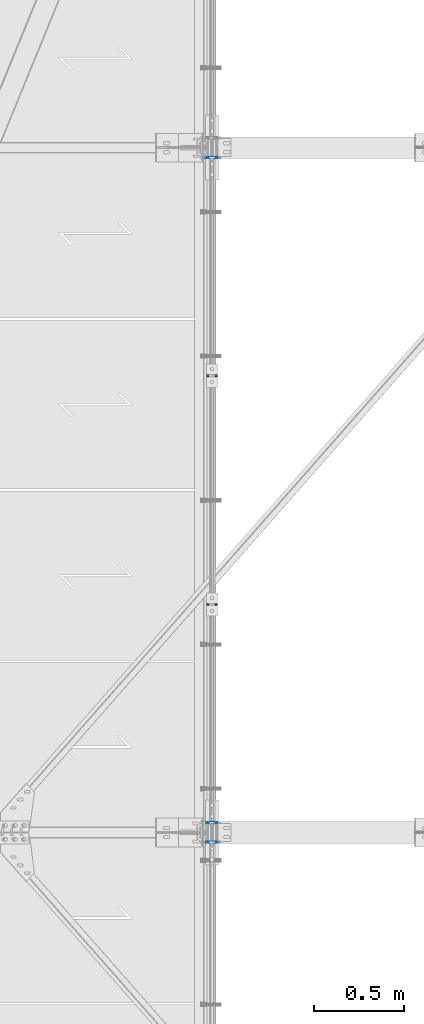
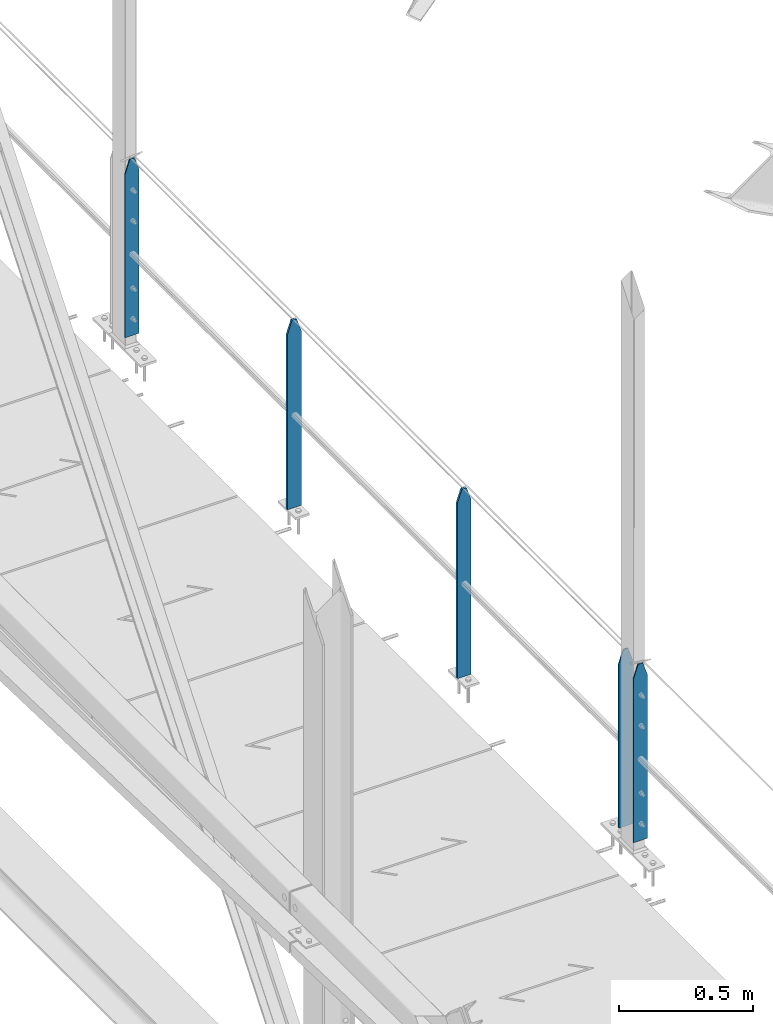
# One storey, part 25 of 496: 5 columns, 2 elements without a shape of their own.
"""IFC2X3 building model written with IfcOpenShell, lengths in millimetres."""

from ifc_helpers import new_model, si_unit, frame, origin_with_axes, origin_2d_with_axis, place, context, subcontext, project, spatial, rectangle, extrude, clip, halfspace, material, type_object, element, aggregate, save


model = new_model("IFC2X3")

# Units and contexts
model_context = context("Model", 3, precision=1e-05, world=origin_with_axes())
body_context = subcontext(model_context, "Body", "Model", "MODEL_VIEW")
ifc_project = project(units=[si_unit("LENGTHUNIT", "METRE", prefix="MILLI"), si_unit("AREAUNIT", "SQUARE_METRE"), si_unit("VOLUMEUNIT", "CUBIC_METRE"), si_unit("MASSUNIT", "GRAM", prefix="KILO"), si_unit("TIMEUNIT", "SECOND"), si_unit("PLANEANGLEUNIT", "RADIAN"), si_unit("SOLIDANGLEUNIT", "STERADIAN"), si_unit("THERMODYNAMICTEMPERATUREUNIT", "DEGREE_CELSIUS"), si_unit("LUMINOUSINTENSITYUNIT", "LUMEN")], contexts=[model_context])

# Site, building, storey
site_placement = place(None, origin_with_axes())
site = spatial("IfcSite", under=ifc_project, at=site_placement, CompositionType="ELEMENT")
building_placement = place(site_placement, origin_with_axes())
building = spatial("IfcBuilding", under=site, at=building_placement, Name="Undefined", CompositionType="ELEMENT")
storey_placement = place(building_placement, origin_with_axes())
storey = spatial("IfcBuildingStorey", under=building, at=storey_placement, Name="Undefined", CompositionType="ELEMENT", Elevation=0.0)

# Assembly, columns
assembly_1_placement = place(storey_placement, origin_with_axes())
assembly_1 = element("IfcElementAssembly", 1, at=assembly_1_placement, inside=storey, Name="MAIN COURANTE", AssemblyPlace="NOTDEFINED", PredefinedType="NOTDEFINED")
ifc_material = material(Name="Undefined/S235-E24")
column_type_1 = type_object("IfcColumnType", PredefinedType="NOTDEFINED")
column_1_placement = place(assembly_1_placement, frame((13993.9998889242, 8865.00344717001, 8250.00000282181), z_axis=(0.0, 0.0, 1.0), x_axis=(1.0, 0.0, 0.0)))
column_1 = element("IfcColumn", 2, at=column_1_placement, type_object=column_type_1, material=ifc_material, Name="MONTANT", context=body_context, shape_type="Clipping", body=[
    clip(clip(extrude(rectangle(XDim=10.0, YDim=60.0, at=origin_2d_with_axis()), frame((0.0, 0.0, 857.599997130677), z_axis=(0.0, 0.0, -1.0), x_axis=(0.0, 1.0, 0.0)), (0.0, 0.0, 1.0), 857.6), halfspace(frame((30.0000001657245, -5.000000004674, 797.599997170884), z_axis=(0.948683298050514, 0.0, 0.316227766016838), x_axis=(-0.316227766016838, 0.0, 0.948683298050514)), False)), halfspace(frame((-29.9999998342682, 4.99999999524351, 797.599997177174), z_axis=(-0.948683298050514, 0.0, 0.316227766016838), x_axis=(0.316227766016838, 0.0, 0.948683298050514)), False)),
])
column_2_placement = place(assembly_1_placement, frame((13993.9998899787, 10135.00344717, 8250.00000195113), z_axis=(0.0, 0.0, 1.0), x_axis=(1.0, 0.0, 0.0)))
column_2 = element("IfcColumn", 3, at=column_2_placement, type_object=column_type_1, material=ifc_material, Name="MONTANT", context=body_context, shape_type="Clipping", body=[
    clip(clip(extrude(rectangle(XDim=10.0, YDim=60.0, at=origin_2d_with_axis()), frame((0.0, 0.0, 857.599997130677), z_axis=(0.0, 0.0, -1.0), x_axis=(0.0, 1.0, 0.0)), (0.0, 0.0, 1.0), 857.6), halfspace(frame((30.0000001657245, -5.000000004674, 797.599997170884), z_axis=(0.948683298050514, 0.0, 0.316227766016838), x_axis=(-0.316227766016838, 0.0, 0.948683298050514)), False)), halfspace(frame((-29.9999998342682, 4.99999999524351, 797.599997177174), z_axis=(-0.948683298050514, 0.0, 0.316227766016838), x_axis=(0.316227766016838, 0.0, 0.948683298050514)), False)),
])

# Assembly, column
assembly_2_placement = place(storey_placement, origin_with_axes())
assembly_2 = element("IfcElementAssembly", 4, at=assembly_2_placement, inside=storey, Name="MAIN COURANTE", AssemblyPlace="NOTDEFINED", PredefinedType="NOTDEFINED")
column_type_2 = type_object("IfcColumnType", PredefinedType="NOTDEFINED")
column_3_placement = place(assembly_2_placement, frame((13993.9998881899, 7545.00000892015, 8300.00000380124), z_axis=(0.0, 0.0, 1.0), x_axis=(1.0, 0.0, 0.0)))
column_3 = element("IfcColumn", 5, at=column_3_placement, type_object=column_type_2, material=ifc_material, Name="MONTANT", context=body_context, shape_type="Clipping", body=[
    clip(clip(extrude(rectangle(XDim=5.0, YDim=60.0, at=origin_2d_with_axis()), frame((0.0, 0.0, 807.599997128624), z_axis=(0.0, 0.0, -1.0), x_axis=(0.0, 1.0, 0.0)), (0.0, 0.0, 1.0), 807.6), halfspace(frame((29.9999999717475, -5.00000000468981, 747.599997131425), z_axis=(0.948683298050514, 0.0, 0.316227766016838), x_axis=(-0.316227766016838, 0.0, 0.948683298050514)), False)), halfspace(frame((-30.000000028238, 4.99999999522788, 747.599997137713), z_axis=(-0.948683298050514, 0.0, 0.316227766016838), x_axis=(0.316227766016838, 0.0, 0.948683298050514)), False)),
])
aggregate(assembly_2, [column_3])

# Column
column_4_placement = place(assembly_1_placement, frame((13993.9998882711, 7655.00000891109, 8300.00000372369), z_axis=(0.0, 0.0, 1.0), x_axis=(1.0, 0.0, 0.0)))
column_4 = element("IfcColumn", 6, at=column_4_placement, type_object=column_type_2, material=ifc_material, Name="MONTANT", context=body_context, shape_type="Clipping", body=[
    clip(clip(extrude(rectangle(XDim=5.0, YDim=60.0, at=origin_2d_with_axis()), frame((0.0, 0.0, 807.599997128624), z_axis=(0.0, 0.0, -1.0), x_axis=(0.0, 1.0, 0.0)), (0.0, 0.0, 1.0), 807.6), halfspace(frame((29.9999999717475, -5.00000000468981, 747.599997131425), z_axis=(0.948683298050514, 0.0, 0.316227766016838), x_axis=(-0.316227766016838, 0.0, 0.948683298050514)), False)), halfspace(frame((-30.000000028238, 4.99999999522788, 747.599997137713), z_axis=(-0.948683298050514, 0.0, 0.316227766016838), x_axis=(0.316227766016838, 0.0, 0.948683298050514)), False)),
])

column_5_placement = place(assembly_1_placement, frame((13993.9998908718, 11345.0000089194, 8300.00000109721), z_axis=(0.0, 0.0, 1.0), x_axis=(1.0, 0.0, 0.0)))
column_5 = element("IfcColumn", 7, at=column_5_placement, type_object=column_type_2, material=ifc_material, Name="MONTANT", context=body_context, shape_type="Clipping", body=[
    clip(clip(extrude(rectangle(XDim=5.0, YDim=60.0, at=origin_2d_with_axis()), frame((0.0, 0.0, 807.599997128624), z_axis=(0.0, 0.0, -1.0), x_axis=(0.0, 1.0, 0.0)), (0.0, 0.0, 1.0), 807.6), halfspace(frame((29.9999999717475, -5.00000000468981, 747.599997131425), z_axis=(0.948683298050514, 0.0, 0.316227766016838), x_axis=(-0.316227766016838, 0.0, 0.948683298050514)), False)), halfspace(frame((-30.000000028238, 4.99999999522788, 747.599997137713), z_axis=(-0.948683298050514, 0.0, 0.316227766016838), x_axis=(0.316227766016838, 0.0, 0.948683298050514)), False)),
])

aggregate(assembly_1, [column_4, column_1, column_5, column_2])

save(model, "model.ifc")
